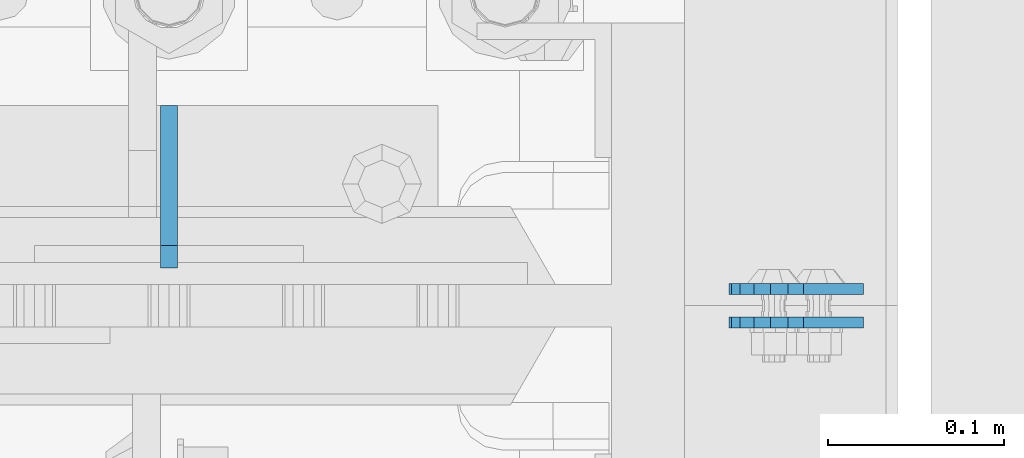
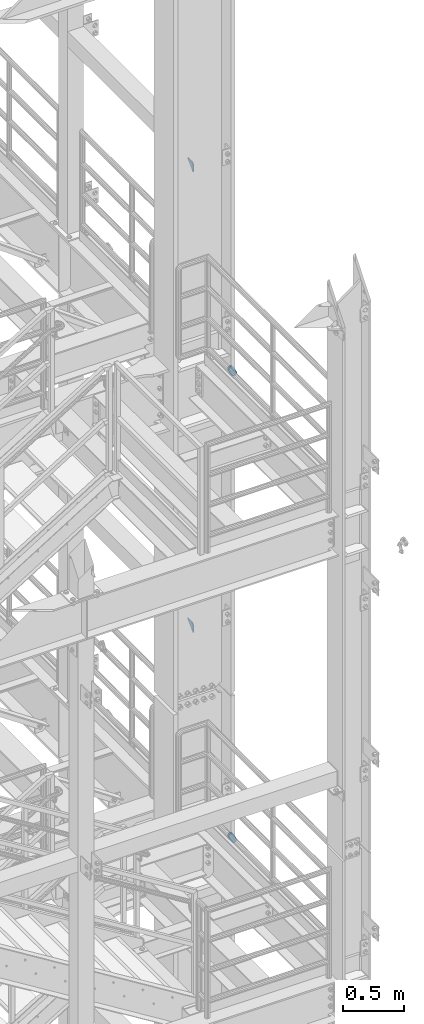
# One storey, part 1523 of 1876: 6 plates, 5 elements without a shape of their own.
"""IFC2X3 building model written with IfcOpenShell, lengths in millimetres."""

from ifc_helpers import new_model, si_unit, frame, origin_with_axes, place, context, subcontext, project, spatial, faceted_brep, material, type_object, element, aggregate, save


model = new_model("IFC2X3")

# Units and contexts
model_context = context("Model", 3, precision=1e-05, world=origin_with_axes())
body_context = subcontext(model_context, "Body", "Model", "MODEL_VIEW")
ifc_project = project(units=[si_unit("LENGTHUNIT", "METRE", prefix="MILLI"), si_unit("AREAUNIT", "SQUARE_METRE"), si_unit("VOLUMEUNIT", "CUBIC_METRE"), si_unit("MASSUNIT", "GRAM", prefix="KILO"), si_unit("TIMEUNIT", "SECOND"), si_unit("PLANEANGLEUNIT", "RADIAN"), si_unit("SOLIDANGLEUNIT", "STERADIAN"), si_unit("THERMODYNAMICTEMPERATUREUNIT", "DEGREE_CELSIUS"), si_unit("LUMINOUSINTENSITYUNIT", "LUMEN")], contexts=[model_context])

# Site, building, storey
site_placement = place(None, origin_with_axes())
site = spatial("IfcSite", under=ifc_project, at=site_placement, CompositionType="ELEMENT")
building_placement = place(site_placement, origin_with_axes())
building = spatial("IfcBuilding", under=site, at=building_placement, Name="Undefined", CompositionType="ELEMENT")
storey_placement = place(building_placement, origin_with_axes())
storey = spatial("IfcBuildingStorey", under=building, at=storey_placement, Name="Undefined", CompositionType="ELEMENT", Elevation=0.0)

# Assembly, plate
assembly_1_placement = place(storey_placement, origin_with_axes())
assembly_1 = element("IfcElementAssembly", 1, at=assembly_1_placement, inside=storey, Name="PLATE", AssemblyPlace="NOTDEFINED", PredefinedType="RIGID_FRAME")
ifc_material = material(Name="STEEL/A36")
plate_type_1 = type_object("IfcPlateType", PredefinedType="NOTDEFINED")
plate_1_placement = place(assembly_1_placement, frame((7974.1626510486, -4581.524993873, 17725.1776774809), z_axis=(-0.894427191199917, 1.49999996210681e-08, -0.447213595099955), x_axis=(0.447213595099955, -6.99999707257281e-09, -0.894427191199917)))
plate_1 = element("IfcPlate", 2, at=plate_1_placement, type_object=plate_type_1, material=ifc_material, Name="PLATE", context=body_context, shape_type="Brep", body=[
    faceted_brep([(-8.59611645864788e-07, -3.17499999999654, 25.3999987589127), (1.93345873884391, -3.17499999999382, 35.1201580589886), (1.93345873884391, 3.17500000000564, 35.1201580589886), (-8.59611645864788e-07, 3.17500000000382, 25.3999987589132), (7.43948648259902, -3.17499999999109, 43.3605112870105), (7.43948648259902, 3.17500000000928, 43.3605112870105), (15.6798395242777, -3.17499999998654, 48.8665393096448), (15.6798395242777, 3.17500000001382, 48.8665393096448), (25.3999987589095, -3.17499999998199, 50.7999992370592), (25.3999987589095, 3.17500000001837, 50.7999992370592), (82.196130752618, -3.17499999998381, 50.7999992370605), (82.196130752618, 3.17500000001655, 50.7999992370642), (91.9162897887145, -3.17499999997926, 48.8665393918873), (91.9162897887145, 3.1750000000211, 48.8665393918909), (100.156642725027, -3.17499999997472, 43.3605115909359), (100.156642725027, 3.17500000002565, 43.3605115909395), (105.662670525982, -3.17499999997108, 35.1201586546285), (105.662670525986, 3.17500000002929, 35.1201586546358), (107.596130371159, -3.17499999996744, 25.3999996185757), (107.596130371159, 3.17500000003292, 25.3999996185794), (105.662670525981, -3.17499999996471, 15.6798405824902), (105.662670525981, 3.17500000003565, 15.6798405824939), (100.156642725024, -3.17499999996471, 7.43948764618654), (100.156642725025, 3.17500000003565, 7.43948764619017), (91.9162897887127, -3.17499999996562, 1.93345984522784), (91.9162897887127, 3.17500000003474, 1.93345984523148), (82.196130752618, -3.17499999996835, 4.54747350886464e-11), (82.196130752618, 3.1750000000311, 4.91127138957381e-11), (25.399998758905, -3.17499999999018, -8.64019966684282e-12), (25.399998758905, 3.17500000001019, -8.64019966684282e-12), (15.679839921364, -3.17499999999382, 1.9334597629304), (15.679839921364, 3.17500000000655, 1.9334597629304), (7.43948709043525, -3.17499999999654, 7.43948734220839), (7.43948709043525, 3.17500000000382, 7.43948734220885), (1.93345923228208, -3.17499999999654, 15.6798399868012), (1.93345923228208, 3.17500000000291, 15.6798399868012)], [[[0, 1, 2, 3]], [[1, 4, 5, 2]], [[4, 6, 7, 5]], [[6, 8, 9, 7]], [[8, 10, 11, 9]], [[10, 12, 13, 11]], [[12, 14, 15, 13]], [[14, 16, 17, 15]], [[16, 18, 19, 17]], [[18, 20, 21, 19]], [[20, 22, 23, 21]], [[22, 24, 25, 23]], [[24, 26, 27, 25]], [[26, 28, 29, 27]], [[28, 30, 31, 29]], [[30, 32, 33, 31]], [[32, 34, 35, 33]], [[34, 0, 3, 35]], [[5, 7, 9, 11, 13, 15, 17, 19, 21, 23, 25, 27, 29, 31, 33, 35, 3, 2]], [[34, 32, 30, 28, 26, 24, 22, 20, 18, 16, 14, 12, 10, 8, 6, 4, 1, 0]]]),
])
aggregate(assembly_1, [plate_1])

assembly_2_placement = place(storey_placement, origin_with_axes())
assembly_2 = element("IfcElementAssembly", 3, at=assembly_2_placement, inside=storey, Name="PLATE", AssemblyPlace="NOTDEFINED", PredefinedType="RIGID_FRAME")
plate_2_placement = place(assembly_2_placement, frame((7974.16265164518, -4562.46379756832, 17725.1776774809), z_axis=(-0.894427191199917, 1.49999996210681e-08, -0.447213595099955), x_axis=(0.447213595099955, -6.99999707257281e-09, -0.894427191199917)))
plate_2 = element("IfcPlate", 4, at=plate_2_placement, type_object=plate_type_1, material=ifc_material, Name="PLATE", context=body_context, shape_type="Brep", body=[
    faceted_brep([(-8.59611645864788e-07, -3.17499999999654, 25.3999987589127), (1.93345873884391, -3.17499999999382, 35.1201580589886), (1.93345873884391, 3.17500000000564, 35.1201580589886), (-8.59611645864788e-07, 3.17500000000382, 25.3999987589132), (7.43948648259902, -3.17499999999109, 43.3605112870105), (7.43948648259902, 3.17500000000928, 43.3605112870105), (15.6798395242777, -3.17499999998654, 48.8665393096448), (15.6798395242777, 3.17500000001382, 48.8665393096448), (25.3999987589095, -3.17499999998199, 50.7999992370592), (25.3999987589095, 3.17500000001837, 50.7999992370592), (82.196130752618, -3.17499999998381, 50.7999992370605), (82.196130752618, 3.17500000001655, 50.7999992370642), (91.9162897887145, -3.17499999997926, 48.8665393918873), (91.9162897887145, 3.1750000000211, 48.8665393918909), (100.156642725027, -3.17499999997472, 43.3605115909359), (100.156642725027, 3.17500000002565, 43.3605115909395), (105.662670525982, -3.17499999997108, 35.1201586546285), (105.662670525986, 3.17500000002929, 35.1201586546358), (107.596130371159, -3.17499999996744, 25.3999996185757), (107.596130371159, 3.17500000003292, 25.3999996185794), (105.662670525981, -3.17499999996471, 15.6798405824902), (105.662670525981, 3.17500000003565, 15.6798405824939), (100.156642725024, -3.17499999996471, 7.43948764618654), (100.156642725025, 3.17500000003565, 7.43948764619017), (91.9162897887127, -3.17499999996562, 1.93345984522784), (91.9162897887127, 3.17500000003474, 1.93345984523148), (82.196130752618, -3.17499999996835, 4.54747350886464e-11), (82.196130752618, 3.1750000000311, 4.91127138957381e-11), (25.399998758905, -3.17499999999018, -8.64019966684282e-12), (25.399998758905, 3.17500000001019, -8.64019966684282e-12), (15.679839921364, -3.17499999999382, 1.9334597629304), (15.679839921364, 3.17500000000655, 1.9334597629304), (7.43948709043525, -3.17499999999654, 7.43948734220839), (7.43948709043525, 3.17500000000382, 7.43948734220885), (1.93345923228208, -3.17499999999654, 15.6798399868012), (1.93345923228208, 3.17500000000291, 15.6798399868012)], [[[0, 1, 2, 3]], [[1, 4, 5, 2]], [[4, 6, 7, 5]], [[6, 8, 9, 7]], [[8, 10, 11, 9]], [[10, 12, 13, 11]], [[12, 14, 15, 13]], [[14, 16, 17, 15]], [[16, 18, 19, 17]], [[18, 20, 21, 19]], [[20, 22, 23, 21]], [[22, 24, 25, 23]], [[24, 26, 27, 25]], [[26, 28, 29, 27]], [[28, 30, 31, 29]], [[30, 32, 33, 31]], [[32, 34, 35, 33]], [[34, 0, 3, 35]], [[5, 7, 9, 11, 13, 15, 17, 19, 21, 23, 25, 27, 29, 31, 33, 35, 3, 2]], [[34, 32, 30, 28, 26, 24, 22, 20, 18, 16, 14, 12, 10, 8, 6, 4, 1, 0]]]),
])
aggregate(assembly_2, [plate_2])

assembly_3_placement = place(storey_placement, origin_with_axes())
assembly_3 = element("IfcElementAssembly", 5, at=assembly_3_placement, inside=storey, Name="PLATE", AssemblyPlace="NOTDEFINED", PredefinedType="RIGID_FRAME")
plate_3_placement = place(assembly_3_placement, frame((7974.1626510486, -4581.524993873, 13038.8776774809), z_axis=(-0.894427191199917, 1.49999996210681e-08, -0.447213595099955), x_axis=(0.447213595099955, -6.99999707257281e-09, -0.894427191199917)))
plate_3 = element("IfcPlate", 6, at=plate_3_placement, type_object=plate_type_1, material=ifc_material, Name="PLATE", context=body_context, shape_type="Brep", body=[
    faceted_brep([(-8.59611645864788e-07, -3.17499999999654, 25.3999987589127), (1.93345873884391, -3.17499999999382, 35.1201580589886), (1.93345873884391, 3.17500000000564, 35.1201580589886), (-8.59611645864788e-07, 3.17500000000382, 25.3999987589132), (7.43948648259902, -3.17499999999109, 43.3605112870105), (7.43948648259902, 3.17500000000928, 43.3605112870105), (15.6798395242777, -3.17499999998654, 48.8665393096448), (15.6798395242777, 3.17500000001382, 48.8665393096448), (25.3999987589095, -3.17499999998199, 50.7999992370592), (25.3999987589095, 3.17500000001837, 50.7999992370592), (82.196130752618, -3.17499999998381, 50.7999992370605), (82.196130752618, 3.17500000001655, 50.7999992370642), (91.9162897887145, -3.17499999997926, 48.8665393918873), (91.9162897887145, 3.1750000000211, 48.8665393918909), (100.156642725027, -3.17499999997472, 43.3605115909359), (100.156642725027, 3.17500000002565, 43.3605115909395), (105.662670525982, -3.17499999997108, 35.1201586546285), (105.662670525986, 3.17500000002929, 35.1201586546358), (107.596130371159, -3.17499999996744, 25.3999996185757), (107.596130371159, 3.17500000003292, 25.3999996185794), (105.662670525981, -3.17499999996471, 15.6798405824902), (105.662670525981, 3.17500000003565, 15.6798405824939), (100.156642725024, -3.17499999996471, 7.43948764618654), (100.156642725025, 3.17500000003565, 7.43948764619017), (91.9162897887127, -3.17499999996562, 1.93345984522784), (91.9162897887127, 3.17500000003474, 1.93345984523148), (82.196130752618, -3.17499999996835, 4.54747350886464e-11), (82.196130752618, 3.1750000000311, 4.91127138957381e-11), (25.399998758905, -3.17499999999018, -8.64019966684282e-12), (25.399998758905, 3.17500000001019, -8.64019966684282e-12), (15.679839921364, -3.17499999999382, 1.9334597629304), (15.679839921364, 3.17500000000655, 1.9334597629304), (7.43948709043525, -3.17499999999654, 7.43948734220839), (7.43948709043525, 3.17500000000382, 7.43948734220885), (1.93345923228208, -3.17499999999654, 15.6798399868012), (1.93345923228208, 3.17500000000291, 15.6798399868012)], [[[0, 1, 2, 3]], [[1, 4, 5, 2]], [[4, 6, 7, 5]], [[6, 8, 9, 7]], [[8, 10, 11, 9]], [[10, 12, 13, 11]], [[12, 14, 15, 13]], [[14, 16, 17, 15]], [[16, 18, 19, 17]], [[18, 20, 21, 19]], [[20, 22, 23, 21]], [[22, 24, 25, 23]], [[24, 26, 27, 25]], [[26, 28, 29, 27]], [[28, 30, 31, 29]], [[30, 32, 33, 31]], [[32, 34, 35, 33]], [[34, 0, 3, 35]], [[5, 7, 9, 11, 13, 15, 17, 19, 21, 23, 25, 27, 29, 31, 33, 35, 3, 2]], [[34, 32, 30, 28, 26, 24, 22, 20, 18, 16, 14, 12, 10, 8, 6, 4, 1, 0]]]),
])
aggregate(assembly_3, [plate_3])

assembly_4_placement = place(storey_placement, origin_with_axes())
assembly_4 = element("IfcElementAssembly", 7, at=assembly_4_placement, inside=storey, Name="PLATE", AssemblyPlace="NOTDEFINED", PredefinedType="RIGID_FRAME")
plate_4_placement = place(assembly_4_placement, frame((7974.16265164519, -4562.46379756832, 13038.8776774809), z_axis=(-0.894427191199917, 1.49999996210681e-08, -0.447213595099955), x_axis=(0.447213595099955, -6.99999707257281e-09, -0.894427191199917)))
plate_4 = element("IfcPlate", 8, at=plate_4_placement, type_object=plate_type_1, material=ifc_material, Name="PLATE", context=body_context, shape_type="Brep", body=[
    faceted_brep([(-8.59611645864788e-07, -3.17499999999654, 25.3999987589127), (1.93345873884391, -3.17499999999382, 35.1201580589886), (1.93345873884391, 3.17500000000564, 35.1201580589886), (-8.59611645864788e-07, 3.17500000000382, 25.3999987589132), (7.43948648259902, -3.17499999999109, 43.3605112870105), (7.43948648259902, 3.17500000000928, 43.3605112870105), (15.6798395242777, -3.17499999998654, 48.8665393096448), (15.6798395242777, 3.17500000001382, 48.8665393096448), (25.3999987589095, -3.17499999998199, 50.7999992370592), (25.3999987589095, 3.17500000001837, 50.7999992370592), (82.196130752618, -3.17499999998381, 50.7999992370605), (82.196130752618, 3.17500000001655, 50.7999992370642), (91.9162897887145, -3.17499999997926, 48.8665393918873), (91.9162897887145, 3.1750000000211, 48.8665393918909), (100.156642725027, -3.17499999997472, 43.3605115909359), (100.156642725027, 3.17500000002565, 43.3605115909395), (105.662670525982, -3.17499999997108, 35.1201586546285), (105.662670525986, 3.17500000002929, 35.1201586546358), (107.596130371159, -3.17499999996744, 25.3999996185757), (107.596130371159, 3.17500000003292, 25.3999996185794), (105.662670525981, -3.17499999996471, 15.6798405824902), (105.662670525981, 3.17500000003565, 15.6798405824939), (100.156642725024, -3.17499999996471, 7.43948764618654), (100.156642725025, 3.17500000003565, 7.43948764619017), (91.9162897887127, -3.17499999996562, 1.93345984522784), (91.9162897887127, 3.17500000003474, 1.93345984523148), (82.196130752618, -3.17499999996835, 4.54747350886464e-11), (82.196130752618, 3.1750000000311, 4.91127138957381e-11), (25.399998758905, -3.17499999999018, -8.64019966684282e-12), (25.399998758905, 3.17500000001019, -8.64019966684282e-12), (15.679839921364, -3.17499999999382, 1.9334597629304), (15.679839921364, 3.17500000000655, 1.9334597629304), (7.43948709043525, -3.17499999999654, 7.43948734220839), (7.43948709043525, 3.17500000000382, 7.43948734220885), (1.93345923228208, -3.17499999999654, 15.6798399868012), (1.93345923228208, 3.17500000000291, 15.6798399868012)], [[[0, 1, 2, 3]], [[1, 4, 5, 2]], [[4, 6, 7, 5]], [[6, 8, 9, 7]], [[8, 10, 11, 9]], [[10, 12, 13, 11]], [[12, 14, 15, 13]], [[14, 16, 17, 15]], [[16, 18, 19, 17]], [[18, 20, 21, 19]], [[20, 22, 23, 21]], [[22, 24, 25, 23]], [[24, 26, 27, 25]], [[26, 28, 29, 27]], [[28, 30, 31, 29]], [[30, 32, 33, 31]], [[32, 34, 35, 33]], [[34, 0, 3, 35]], [[5, 7, 9, 11, 13, 15, 17, 19, 21, 23, 25, 27, 29, 31, 33, 35, 3, 2]], [[34, 32, 30, 28, 26, 24, 22, 20, 18, 16, 14, 12, 10, 8, 6, 4, 1, 0]]]),
])
aggregate(assembly_4, [plate_4])

# Assembly, plates
assembly_5_placement = place(storey_placement, origin_with_axes())
assembly_5 = element("IfcElementAssembly", 9, at=assembly_5_placement, inside=storey, Name="COLUMN", AssemblyPlace="NOTDEFINED", PredefinedType="RIGID_FRAME")
plate_type_2 = type_object("IfcPlateType", PredefinedType="NOTDEFINED")
plate_5_placement = place(assembly_5_placement, frame((7620.0, -4458.49374940317, 19862.8), z_axis=(0.0, -0.707106781186548, 0.707106781186548), x_axis=(0.0, -0.707106781186548, -0.707106781186548)))
plate_5 = element("IfcPlate", 10, at=plate_5_placement, type_object=plate_type_2, material=ifc_material, Name="PLATE", context=body_context, shape_type="Brep", body=[
    faceted_brep([(0.0, -4.76249999999982, 0.0), (56.1266013136901, -4.76249999997708, 56.1266013135391), (56.1266013136883, 4.76250000002256, 56.1266013135428), (0.0, 4.76249999999982, 0.0), (74.0871132860975, -4.7624999999698, 56.1266013135246), (74.0871132860993, 4.76250000002983, 56.1266013135282), (130.213714599717, -4.76249999994707, -1.30967237055302e-10), (130.213714599715, 4.76250000005257, -1.23691279441118e-10)], [[[0, 1, 2, 3]], [[1, 4, 5, 2]], [[4, 6, 7, 5]], [[6, 0, 3, 7]], [[5, 7, 3, 2]], [[6, 4, 1, 0]]]),
])
plate_6_placement = place(assembly_5_placement, frame((7620.0, -4458.49374940317, 15240.0), z_axis=(0.0, -0.707106781186548, 0.707106781186548), x_axis=(0.0, -0.707106781186548, -0.707106781186548)))
plate_6 = element("IfcPlate", 11, at=plate_6_placement, type_object=plate_type_2, material=ifc_material, Name="PLATE", context=body_context, shape_type="Brep", body=[
    faceted_brep([(0.0, -4.76249999999982, 0.0), (56.1266013136901, -4.76249999997708, 56.1266013135391), (56.1266013136883, 4.76250000002256, 56.1266013135428), (0.0, 4.76249999999982, 0.0), (74.0871132860975, -4.7624999999698, 56.1266013135246), (74.0871132860993, 4.76250000002983, 56.1266013135282), (130.213714599717, -4.76249999994707, -1.30967237055302e-10), (130.213714599715, 4.76250000005257, -1.23691279441118e-10)], [[[0, 1, 2, 3]], [[1, 4, 5, 2]], [[4, 6, 7, 5]], [[6, 0, 3, 7]], [[5, 7, 3, 2]], [[6, 4, 1, 0]]]),
])
aggregate(assembly_5, [plate_5, plate_6])

save(model, "model.ifc")
